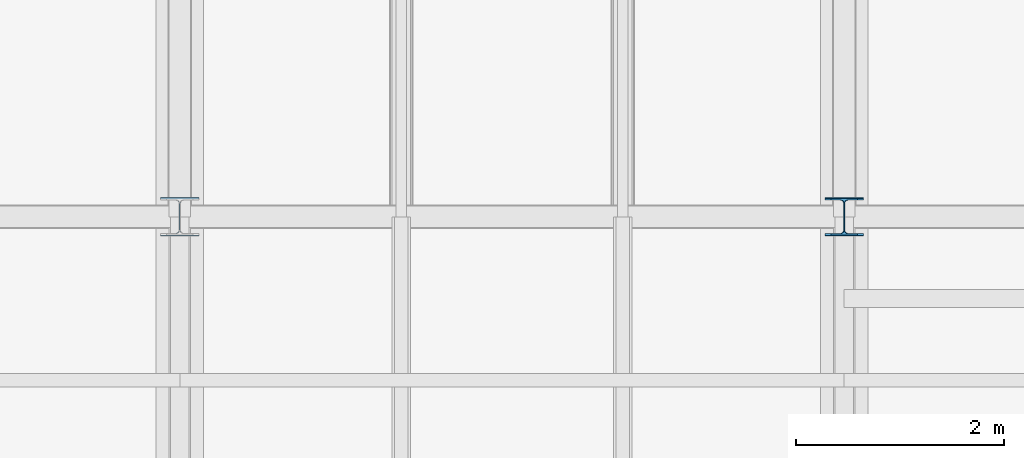
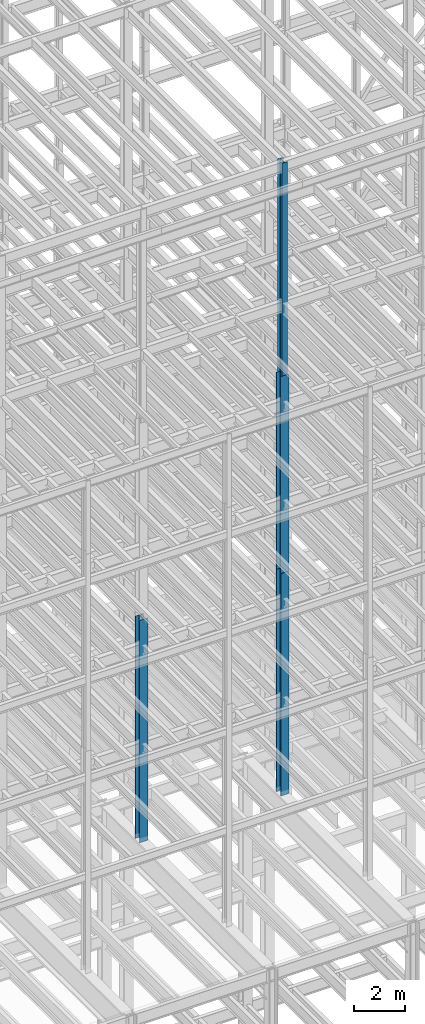
# One storey, part 26 of 150: 4 columns.
"""IFC2X3 building model written with IfcOpenShell, lengths in millimetres."""

from ifc_helpers import new_model, si_unit, frame, origin_with_axes, origin_2d_with_axis, place, context, subcontext, project, spatial, i_section, extrude, material, type_object, element, save


model = new_model("IFC2X3")

# Units and contexts
model_context = context("Model", 3, precision=1e-05, world=origin_with_axes())
body_context = subcontext(model_context, "Body", "Model", "MODEL_VIEW")
ifc_project = project(units=[si_unit("LENGTHUNIT", "METRE", prefix="MILLI"), si_unit("AREAUNIT", "SQUARE_METRE"), si_unit("VOLUMEUNIT", "CUBIC_METRE"), si_unit("MASSUNIT", "GRAM", prefix="KILO"), si_unit("TIMEUNIT", "SECOND"), si_unit("PLANEANGLEUNIT", "RADIAN"), si_unit("SOLIDANGLEUNIT", "STERADIAN"), si_unit("THERMODYNAMICTEMPERATUREUNIT", "DEGREE_CELSIUS"), si_unit("LUMINOUSINTENSITYUNIT", "LUMEN")], contexts=[model_context])

# Site, building, storey
site_placement = place(None, origin_with_axes())
site = spatial("IfcSite", under=ifc_project, at=site_placement, CompositionType="ELEMENT")
building_placement = place(site_placement, origin_with_axes())
building = spatial("IfcBuilding", under=site, at=building_placement, Name="Undefined", CompositionType="ELEMENT")
storey_placement = place(building_placement, origin_with_axes())
storey = spatial("IfcBuildingStorey", under=building, at=storey_placement, Name="Undefined", CompositionType="ELEMENT", Elevation=0.0)

# Columns
ifc_material = material(Name="STEEL/A992")
column_type_1 = type_object("IfcColumnType", Name="W14X61", PredefinedType="NOTDEFINED")
column_1_placement = place(storey_placement, frame((37388.8, 10185.4, 55702.2), z_axis=(0.0, 0.0, 1.0), x_axis=(1.0, 0.0, 0.0)))
element("IfcColumn", 1, at=column_1_placement, inside=storey, type_object=column_type_1, material=ifc_material, Name="COLUMN", ObjectType="W14X61", context=body_context, shape_type="SweptSolid", body=[
    extrude(i_section(OverallWidth=254.0, OverallDepth=352.425, WebThickness=9.5249, FlangeThickness=16.383, FilletRadius=21.717, at=origin_2d_with_axis()), frame((0.0, 0.0, 10210.8), z_axis=(0.0, 0.0, -1.0), x_axis=(-1.0, 0.0, 0.0)), (0.0, 0.0, 1.0), 10210.8),
])
column_type_2 = type_object("IfcColumnType", Name="W14X90", PredefinedType="NOTDEFINED")
column_2_placement = place(storey_placement, frame((37388.8, 10185.4, 46253.4), z_axis=(0.0, 0.0, 1.0), x_axis=(1.0, 0.0, 0.0)))
element("IfcColumn", 2, at=column_2_placement, inside=storey, type_object=column_type_2, material=ifc_material, Name="COLUMN", ObjectType="W14X90", context=body_context, shape_type="SweptSolid", body=[
    extrude(i_section(OverallWidth=368.3, OverallDepth=355.6, WebThickness=11.1125, FlangeThickness=18.034, FilletRadius=32.7659, at=origin_2d_with_axis()), frame((0.0, 0.0, 9448.8), z_axis=(0.0, 0.0, -1.0), x_axis=(-1.0, 0.0, 0.0)), (0.0, 0.0, 1.0), 9448.8),
])
column_type_3 = type_object("IfcColumnType", Name="W14X120", PredefinedType="NOTDEFINED")
for number, where, z_axis, x_axis, name in (
    (3, (37388.8, 10185.4, 35585.4), (0.0, 0.0, 1.0), (1.0, 0.0, 0.0), "COLUMN"),
    (4, (30988.0, 10185.4, 35585.4), (0.0, 0.0, 1.0), (1.0, 0.0, 0.0), "COLUMN"),
):
    element("IfcColumn", number, at=place(storey_placement, frame(where, z_axis=z_axis, x_axis=x_axis)), inside=storey, type_object=column_type_3, material=ifc_material, Name=name, ObjectType="W14X120", context=body_context, shape_type="SweptSolid", body=[
        extrude(i_section(OverallWidth=371.475, OverallDepth=368.3, WebThickness=14.2875, FlangeThickness=23.876, FilletRadius=33.274, at=origin_2d_with_axis()), frame((0.0, 0.0, 10667.9989332), z_axis=(0.0, 0.0, -1.0), x_axis=(-1.0, 0.0, 0.0)), (0.0, 0.0, 1.0), 10667.9989332),
    ])

save(model, "model.ifc")
